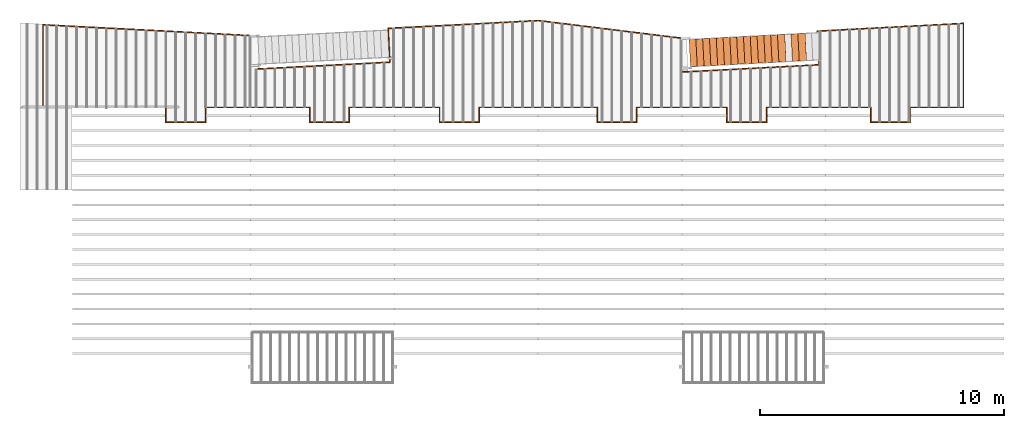
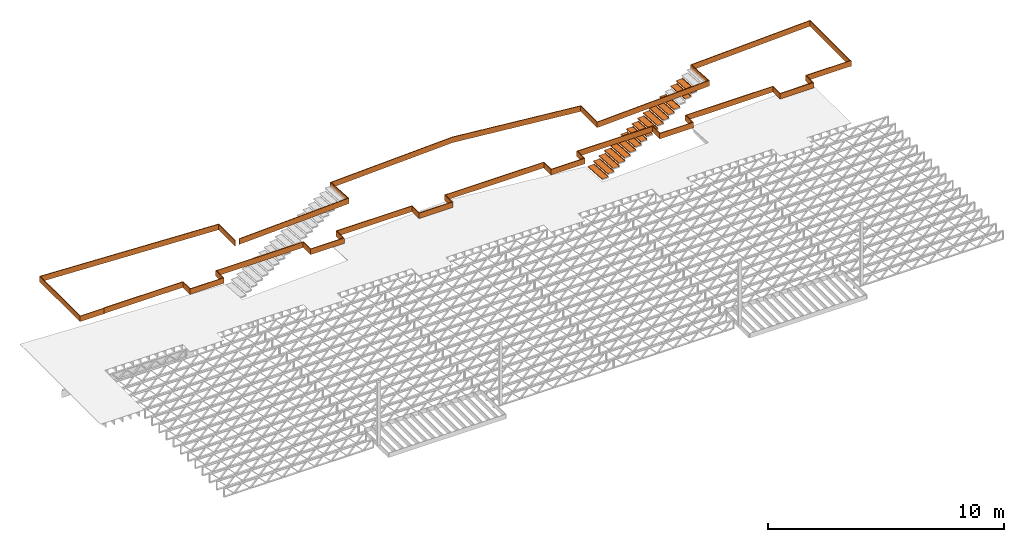
# One storey, part 15 of 23: 18 proxies.
"""IFC4 building model written with IfcOpenShell, lengths in feet."""

from ifc_helpers import new_model, entity, si_unit, converted_unit, derived_unit, direction, frame, origin, place, context, subcontext, project, spatial, polyline, outline, extrude, source, transform, mapped, material, type_object, type_shapes, element, save


model = new_model("IFC4")

# Units and contexts
model_context = context("Model", 3, precision=0.0001, world=origin(), true_north=direction((6.12303176911189e-17, 1.0)))
body_context = subcontext(model_context, "Body", "Model", "MODEL_VIEW")
ifc_project = project(units=[converted_unit("LENGTHUNIT", "FOOT", entity("IfcRatioMeasure", 0.3048), si_unit("LENGTHUNIT", "METRE"), dimensions=[1, 0, 0, 0, 0, 0, 0]), converted_unit("AREAUNIT", "SQUARE FOOT", entity("IfcRatioMeasure", 0.09290304), si_unit("AREAUNIT", "SQUARE_METRE"), dimensions=[2, 0, 0, 0, 0, 0, 0]), converted_unit("VOLUMEUNIT", "CUBIC FOOT", entity("IfcRatioMeasure", 0.028316846592), si_unit("VOLUMEUNIT", "CUBIC_METRE"), dimensions=[3, 0, 0, 0, 0, 0, 0]), converted_unit("PLANEANGLEUNIT", "DEGREE", entity("IfcRatioMeasure", 0.0174532925199433), si_unit("PLANEANGLEUNIT", "RADIAN"), dimensions=[0, 0, 0, 0, 0, 0, 0]), si_unit("MASSUNIT", "GRAM", prefix="KILO"), derived_unit("MASSDENSITYUNIT", [(si_unit("MASSUNIT", "GRAM", prefix="KILO"), 1), (si_unit("LENGTHUNIT", "METRE"), -3)]), derived_unit("MOMENTOFINERTIAUNIT", [(si_unit("LENGTHUNIT", "METRE"), 4)]), si_unit("TIMEUNIT", "SECOND"), si_unit("FREQUENCYUNIT", "HERTZ"), si_unit("THERMODYNAMICTEMPERATUREUNIT", "DEGREE_CELSIUS"), derived_unit("THERMALTRANSMITTANCEUNIT", [(si_unit("MASSUNIT", "GRAM", prefix="KILO"), 1), (si_unit("THERMODYNAMICTEMPERATUREUNIT", "KELVIN"), -1), (si_unit("TIMEUNIT", "SECOND"), -3)]), derived_unit("VOLUMETRICFLOWRATEUNIT", [(si_unit("LENGTHUNIT", "METRE"), 3), (si_unit("TIMEUNIT", "SECOND"), -1)]), si_unit("ELECTRICCURRENTUNIT", "AMPERE"), si_unit("ELECTRICVOLTAGEUNIT", "VOLT"), si_unit("POWERUNIT", "WATT"), si_unit("FORCEUNIT", "NEWTON"), si_unit("ILLUMINANCEUNIT", "LUX"), si_unit("LUMINOUSFLUXUNIT", "LUMEN"), si_unit("LUMINOUSINTENSITYUNIT", "CANDELA"), derived_unit("USERDEFINED", [(si_unit("MASSUNIT", "GRAM", prefix="KILO"), -1), (si_unit("LENGTHUNIT", "METRE"), -2), (si_unit("TIMEUNIT", "SECOND"), 3), (si_unit("LUMINOUSFLUXUNIT", "LUMEN"), 1)]), derived_unit("LINEARVELOCITYUNIT", [(si_unit("LENGTHUNIT", "METRE"), 1), (si_unit("TIMEUNIT", "SECOND"), -1)]), si_unit("PRESSUREUNIT", "PASCAL"), derived_unit("USERDEFINED", [(si_unit("LENGTHUNIT", "METRE"), -2), (si_unit("MASSUNIT", "GRAM", prefix="KILO"), 1), (si_unit("TIMEUNIT", "SECOND"), -2)]), derived_unit("LINEARFORCEUNIT", [(si_unit("MASSUNIT", "GRAM", prefix="KILO"), 1), (si_unit("LENGTHUNIT", "METRE"), 1), (si_unit("TIMEUNIT", "SECOND"), -2), (si_unit("LENGTHUNIT", "METRE"), -1)]), derived_unit("PLANARFORCEUNIT", [(si_unit("MASSUNIT", "GRAM", prefix="KILO"), 1), (si_unit("LENGTHUNIT", "METRE"), 1), (si_unit("TIMEUNIT", "SECOND"), -2), (si_unit("LENGTHUNIT", "METRE"), -2)])], contexts=[model_context])

# Site, building, storey
site_placement = place(None, origin())
site = spatial("IfcSite", under=ifc_project, at=site_placement, CompositionType="ELEMENT")
building_placement = place(site_placement, origin())
building = spatial("IfcBuilding", under=site, at=building_placement, CompositionType="ELEMENT")
storey_placement = place(building_placement, frame((0.0, 0.0, 10.8020833333333)))
storey = spatial("IfcBuildingStorey", under=building, at=storey_placement, Name="2ND FLOOR", CompositionType="ELEMENT", Elevation=10.8020833333333)

# Proxies
ifc_material_1 = material(Name="BRAKE METAL FLASHING AT PERIMETER 2X LEDGER", Category="Materials")
building_element_proxy_type_1 = type_object("IfcBuildingElementProxyType", Name="Structural Framing 10:Structural Framing 10", PredefinedType="NOTDEFINED", material=ifc_material_1)
shared_shape_1 = source(origin(), body_context, "Body", "SweptSolid", [
    extrude(outline(polyline([(-7.56753895396921, -42.2774157655166), (3.87966828565245, -42.2774157655166), (2.84075976230344, -22.4538602254437), (-1.69469338261541, -22.6913475810637), (-2.65710623777287, -4.32741634172971), (1.89079299111185, -4.32741634172969), (4.2646279059843, 15.0059175678136), (3.20329361123053, 35.2573823173956), (-1.33214906717884, 35.0196898385549), (-2.2789485125582, 53.085699471748), (-2.4037772044025, 53.0791574772176), (-1.45043576449265, 34.8883191521804), (3.08500691391683, 35.1260116310211), (4.13922686378191, 15.0102966687023), (1.78020233304241, -4.20241634172977), (-2.7888287534328, -4.20241634172985), (-1.81298037577432, -22.8227126223806), (2.72247276914442, -22.5852252667607), (3.74794576999241, -42.1524157655166), (-7.56753895396921, -42.1524157655166), (-7.56753895396921, -42.2774157655166)])), frame((81.6716675678157, 7.56754075120455, 0.0), z_axis=(0.0, 0.0, 1.0), x_axis=(0.0, 1.0, 0.0)), (0.0, 0.0, 1.0), 0.9375),
    extrude(outline(polyline([(8.04599253803074, -5.11661078283554), (8.04599253803075, -5.24161078283554), (11.9880614770721, -5.24161078283542), (11.9880614770717, 6.03149352153641), (-16.0110697093404, 4.56412123420146), (-16.0110218563282, -0.108947414546855), (-15.8860697093402, -0.115495879087139), (-15.8860697093407, 4.44550066336238), (11.8630614770719, 5.89977100587647), (11.8630614770721, -5.11661078283554), (8.04599253803074, -5.11661078283554)])), frame((11.9880614770724, 5.24161078283623, 0.0), z_axis=(0.0, 0.0, -1.0), x_axis=(-1.0, 0.0, 0.0)), (0.0, 0.0, -1.0), 0.9375),
])
type_shapes(building_element_proxy_type_1, [shared_shape_1])
proxy_1_placement = place(storey_placement, frame((-269.737243818863, 958.903601069585, 9.4687500000001)))
element("IfcBuildingElementProxy", 1, at=proxy_1_placement, inside=storey, type_object=building_element_proxy_type_1, material=ifc_material_1, Name="Structural Framing 10:Structural Framing 10", ObjectType="Structural Framing 10:Structural Framing 10", PredefinedType="NOTDEFINED", context=body_context, shape_type="MappedRepresentation", body=[
    mapped(shared_shape_1, transform((0.0, 0.0, 0.0), scale=1.0)),
])
ifc_material_2 = material(Name="TREATED 2X LEDGER - EXT. STAIN", Category="Materials")
building_element_proxy_type_2 = type_object("IfcBuildingElementProxyType", Name="Structural Framing 30:Structural Framing 10", PredefinedType="NOTDEFINED", material=ifc_material_2)
shared_shape_2 = source(origin(), body_context, "Body", "SweptSolid", [
    extrude(outline(polyline([(-62.5882752409424, -0.860575797798219), (-62.5882752409424, -0.985575797798219), (-49.7925957869951, -0.985575797798219), (-49.7925952844915, 1.01442372247004), (-44.5790513990362, 1.01442372246993), (-44.5790508965316, -0.985580263202678), (-30.4592588644664, -0.985576715578077), (-30.4592593669705, 1.01442372247004), (-25.245716639162, 1.01442372247004), (-25.2457166391621, -0.985579727022696), (-12.9957192201912, -0.98557673237417), (-12.9957197091137, 1.01442372246993), (-7.78738545573532, 1.01442372246981), (-7.78738595421945, -0.985575581580974), (8.21261399126007, -0.985579569456718), (8.21261399126004, 1.01442372247004), (13.4209478126482, 1.01442372247004), (13.4209478126482, -0.985579727024628), (25.6709474765803, -0.985576732373261), (25.6709469876575, 1.01442372246993), (30.8844877145134, 1.01442372247004), (30.884487212011, -0.985575550993076), (45.0042807971791, -0.985579098609605), (45.0042807971789, 1.01442372247027), (50.2126139732988, 1.01442372247038), (50.2126144758024, -0.985575765082217), (57.4959474606437, -0.985577595032396), (57.4959474920499, -0.860577595032169), (50.3376144443961, -0.860575796488433), (50.3376139418926, 1.13942372247061), (44.8792807971786, 1.13942372247061), (44.8792807971788, -0.860579067202821), (31.0094872434177, -0.860575582399179), (31.0094877459201, 1.13942372247027), (25.5459469570995, 1.13942372247027), (25.5459474460225, -0.860576762930805), (13.5459478126485, -0.860579696466743), (13.5459478126485, 1.13942372247038), (8.08761399125981, 1.13942372247027), (8.08761399125981, -0.860579538301181), (-7.66238592306419, -0.860575612736284), (-7.66238542457992, 1.13942372246993), (-13.1207197396713, 1.13942372246981), (-13.1207192507489, -0.860576762931714), (-25.1207166391621, -0.860579696465038), (-25.1207166391621, 1.13942372246993), (-30.584259398377, 1.13942372247004), (-30.584258895873, -0.860576746984407), (-44.4540509279381, -0.860580231796234), (-44.4540514304427, 1.13942372246993), (-49.9175952530849, 1.13942372246993), (-49.9175957555886, -0.860575797798219), (-62.5882752409424, -0.860575797798219)])), frame((62.5882752409424, 1.13942372247061, 0.0), z_axis=(0.0, 0.0, -1.0), x_axis=(1.0, 0.0, 0.0)), (0.0, 0.0, -1.0), 0.9375),
])
type_shapes(building_element_proxy_type_2, [shared_shape_2])
proxy_2_placement = place(storey_placement, frame((-265.872383218523, 956.903601549317, 9.52083333333334)))
element("IfcBuildingElementProxy", 2, at=proxy_2_placement, inside=storey, type_object=building_element_proxy_type_2, material=ifc_material_2, Name="Structural Framing 30:Structural Framing 10", ObjectType="Structural Framing 30:Structural Framing 10", PredefinedType="NOTDEFINED", context=body_context, shape_type="MappedRepresentation", body=[
    mapped(shared_shape_2, transform((0.0, 0.0, 0.0), scale=1.0)),
])
ifc_material_3 = material(Name="GALV. STEEL TREAD", Category="Materials")
building_element_proxy_type_3 = type_object("IfcBuildingElementProxyType", Name="Generic Models 802:Generic Models 629", PredefinedType="NOTDEFINED", material=ifc_material_3)
shared_shape_3 = source(origin(), body_context, "Body", "SweptSolid", [
    extrude(outline(polyline([(-0.597916666666581, 0.02708333333333), (-0.597916666666569, -0.118750000000006), (-0.587499999999929, -0.118750000000006), (-0.587499999999947, 0.0166666666666657), (0.391666666666667, 0.0166666666666657), (0.391666666666679, -0.118750000000006), (0.402083333333376, -0.118750000000006), (0.402083333333369, 0.193750000000001), (0.391666666666649, 0.193750000000001), (0.391666666666667, 0.02708333333333), (-0.597916666666581, 0.02708333333333)])), frame((0.791176413725168, 0.0312925405037277, 0.118750000000009), z_axis=(0.0523359562429694, -0.998629534754573, 0.0), x_axis=(0.998629534754573, 0.0523359562429694, 0.0)), (0.0, 0.0, -1.0), 3.70833333337879),
])
type_shapes(building_element_proxy_type_3, [shared_shape_3])
proxy_3_placement = place(storey_placement, frame((-171.796644235969, 965.013307028824, 6.41392543859246)))
element("IfcBuildingElementProxy", 3, at=proxy_3_placement, inside=storey, type_object=building_element_proxy_type_3, material=ifc_material_3, Name="Generic Models 802:Generic Models 629", ObjectType="Generic Models 802:Generic Models 629", PredefinedType="NOTDEFINED", context=body_context, shape_type="MappedRepresentation", body=[
    mapped(shared_shape_3, transform((0.0, 0.0, 0.0), scale=1.0)),
])
building_element_proxy_type_4 = type_object("IfcBuildingElementProxyType", Name="Generic Models 808:Generic Models 629", PredefinedType="NOTDEFINED", material=ifc_material_3)
shared_shape_4 = source(origin(), body_context, "Body", "SweptSolid", [
    extrude(outline(polyline([(-0.597916666666581, 0.02708333333333), (-0.597916666666569, -0.118750000000006), (-0.587499999999929, -0.118750000000006), (-0.587499999999947, 0.0166666666666657), (0.391666666666667, 0.0166666666666657), (0.391666666666679, -0.118750000000006), (0.402083333333376, -0.118750000000006), (0.402083333333369, 0.193750000000001), (0.391666666666649, 0.193750000000001), (0.391666666666667, 0.02708333333333), (-0.597916666666581, 0.02708333333333)])), frame((0.791176413725168, 0.031292540503614, 0.118750000000006), z_axis=(0.0523359562429694, -0.998629534754573, 0.0), x_axis=(0.998629534754573, 0.0523359562429694, 0.0)), (0.0, 0.0, -1.0), 3.70833333337879),
])
type_shapes(building_element_proxy_type_4, [shared_shape_4])
proxy_4_placement = place(storey_placement, frame((-168.137157266468, 965.205092614211, 8.6595394736803)))
element("IfcBuildingElementProxy", 4, at=proxy_4_placement, inside=storey, type_object=building_element_proxy_type_4, material=ifc_material_3, Name="Generic Models 808:Generic Models 629", ObjectType="Generic Models 808:Generic Models 629", PredefinedType="NOTDEFINED", context=body_context, shape_type="MappedRepresentation", body=[
    mapped(shared_shape_4, transform((0.0, 0.0, 0.0), scale=1.0)),
])
building_element_proxy_type_5 = type_object("IfcBuildingElementProxyType", Name="Generic Models 810:Generic Models 629", PredefinedType="NOTDEFINED", material=ifc_material_3)
shared_shape_5 = source(origin(), body_context, "Body", "SweptSolid", [
    extrude(outline(polyline([(-0.597916666666581, 0.0270833333333336), (-0.597916666666569, -0.118750000000002), (-0.587499999999929, -0.118750000000002), (-0.587499999999947, 0.0166666666666693), (0.391666666666667, 0.0166666666666693), (0.391666666666679, -0.118750000000002), (0.402083333333376, -0.118750000000002), (0.402083333333369, 0.193750000000005), (0.391666666666649, 0.193750000000005), (0.391666666666667, 0.0270833333333336), (-0.597916666666581, 0.0270833333333336)])), frame((0.791176413725168, 0.0312925405038413, 0.118750000000002), z_axis=(0.0523359562429694, -0.998629534754573, 0.0), x_axis=(0.998629534754573, 0.0523359562429694, 0.0)), (0.0, 0.0, -1.0), 3.70833333337879),
])
type_shapes(building_element_proxy_type_5, [shared_shape_5])
proxy_5_placement = place(storey_placement, frame((-169.052029008843, 965.157146217864, 8.09813596490834)))
element("IfcBuildingElementProxy", 5, at=proxy_5_placement, inside=storey, type_object=building_element_proxy_type_5, material=ifc_material_3, Name="Generic Models 810:Generic Models 629", ObjectType="Generic Models 810:Generic Models 629", PredefinedType="NOTDEFINED", context=body_context, shape_type="MappedRepresentation", body=[
    mapped(shared_shape_5, transform((0.0, 0.0, 0.0), scale=1.0)),
])
building_element_proxy_type_6 = type_object("IfcBuildingElementProxyType", Name="Generic Models 814:Generic Models 629", PredefinedType="NOTDEFINED", material=ifc_material_3)
shared_shape_6 = source(origin(), body_context, "Body", "SweptSolid", [
    extrude(outline(polyline([(-0.597916666666581, 0.0270833333333336), (-0.597916666666569, -0.118750000000002), (-0.587499999999929, -0.118750000000002), (-0.587499999999947, 0.0166666666666693), (0.391666666666667, 0.0166666666666693), (0.391666666666679, -0.118750000000002), (0.402083333333376, -0.118750000000002), (0.402083333333369, 0.193750000000005), (0.391666666666649, 0.193750000000005), (0.391666666666667, 0.0270833333333336), (-0.597916666666581, 0.0270833333333336)])), frame((0.791176413725168, 0.0312925405037277, 0.118750000000002), z_axis=(0.0523359562429694, -0.998629534754573, 0.0), x_axis=(0.998629534754573, 0.0523359562429694, 0.0)), (0.0, 0.0, -1.0), 3.70833333337879),
])
type_shapes(building_element_proxy_type_6, [shared_shape_6])
proxy_6_placement = place(storey_placement, frame((-170.881772493594, 965.06125342517, 6.97532894736442)))
element("IfcBuildingElementProxy", 6, at=proxy_6_placement, inside=storey, type_object=building_element_proxy_type_6, material=ifc_material_3, Name="Generic Models 814:Generic Models 629", ObjectType="Generic Models 814:Generic Models 629", PredefinedType="NOTDEFINED", context=body_context, shape_type="MappedRepresentation", body=[
    mapped(shared_shape_6, transform((0.0, 0.0, 0.0), scale=1.0)),
])
building_element_proxy_type_7 = type_object("IfcBuildingElementProxyType", Name="Generic Models 816:Generic Models 629", PredefinedType="NOTDEFINED", material=ifc_material_3)
shared_shape_7 = source(origin(), body_context, "Body", "SweptSolid", [
    extrude(outline(polyline([(-0.597916666666609, 0.0270833333333336), (-0.597916666666598, -0.118750000000002), (-0.587499999999957, -0.118750000000002), (-0.587499999999975, 0.0166666666666693), (0.391666666666639, 0.0166666666666693), (0.39166666666665, -0.118750000000002), (0.402083333333348, -0.118750000000002), (0.40208333333334, 0.193750000000005), (0.391666666666621, 0.193750000000005), (0.391666666666639, 0.0270833333333336), (-0.597916666666609, 0.0270833333333336)])), frame((0.791176413725196, 0.0312925405037277, 0.118750000000002), z_axis=(0.0523359562429694, -0.998629534754573, 0.0), x_axis=(0.998629534754573, 0.0523359562429694, 0.0)), (0.0, 0.0, -1.0), 3.70833333337879),
])
type_shapes(building_element_proxy_type_7, [shared_shape_7])
proxy_7_placement = place(storey_placement, frame((-172.711515978344, 964.965360632477, 5.85252192982051)))
element("IfcBuildingElementProxy", 7, at=proxy_7_placement, inside=storey, type_object=building_element_proxy_type_7, material=ifc_material_3, Name="Generic Models 816:Generic Models 629", ObjectType="Generic Models 816:Generic Models 629", PredefinedType="NOTDEFINED", context=body_context, shape_type="MappedRepresentation", body=[
    mapped(shared_shape_7, transform((0.0, 0.0, 0.0), scale=1.0)),
])
building_element_proxy_type_8 = type_object("IfcBuildingElementProxyType", Name="Generic Models 818:Generic Models 629", PredefinedType="NOTDEFINED", material=ifc_material_3)
shared_shape_8 = source(origin(), body_context, "Body", "SweptSolid", [
    extrude(outline(polyline([(-0.597916666666581, 0.0270833333333336), (-0.597916666666569, -0.118750000000002), (-0.587499999999929, -0.118750000000002), (-0.587499999999947, 0.0166666666666693), (0.391666666666667, 0.0166666666666693), (0.391666666666679, -0.118750000000002), (0.402083333333376, -0.118750000000002), (0.402083333333369, 0.193750000000005), (0.391666666666649, 0.193750000000005), (0.391666666666667, 0.0270833333333336), (-0.597916666666581, 0.0270833333333336)])), frame((0.791176413725168, 0.0312925405037277, 0.118750000000006), z_axis=(0.0523359562429694, -0.998629534754573, 0.0), x_axis=(0.998629534754573, 0.0523359562429694, 0.0)), (0.0, 0.0, -1.0), 3.70833333337879),
])
type_shapes(building_element_proxy_type_8, [shared_shape_8])
proxy_8_placement = place(storey_placement, frame((-173.626387720719, 964.917414236131, 5.29111842104855)))
element("IfcBuildingElementProxy", 8, at=proxy_8_placement, inside=storey, type_object=building_element_proxy_type_8, material=ifc_material_3, Name="Generic Models 818:Generic Models 629", ObjectType="Generic Models 818:Generic Models 629", PredefinedType="NOTDEFINED", context=body_context, shape_type="MappedRepresentation", body=[
    mapped(shared_shape_8, transform((0.0, 0.0, 0.0), scale=1.0)),
])
building_element_proxy_type_9 = type_object("IfcBuildingElementProxyType", Name="Generic Models 820:Generic Models 629", PredefinedType="NOTDEFINED", material=ifc_material_3)
shared_shape_9 = source(origin(), body_context, "Body", "SweptSolid", [
    extrude(outline(polyline([(-0.597916666666609, 0.02708333333333), (-0.597916666666598, -0.118750000000006), (-0.587499999999985, -0.118750000000006), (-0.587499999999975, 0.0166666666666657), (0.391666666666639, 0.0166666666666657), (0.39166666666665, -0.118750000000006), (0.402083333333319, -0.118750000000006), (0.40208333333334, 0.193750000000001), (0.391666666666621, 0.193750000000001), (0.391666666666639, 0.02708333333333), (-0.597916666666609, 0.02708333333333)])), frame((0.791176413725196, 0.031292540503955, 0.118750000000004), z_axis=(0.0523359562429694, -0.998629534754573, 0.0), x_axis=(0.998629534754573, 0.0523359562429694, 0.0)), (0.0, 0.0, -1.0), 3.70833333337879),
])
type_shapes(building_element_proxy_type_9, [shared_shape_9])
proxy_9_placement = place(storey_placement, frame((-174.541259463095, 964.869467839784, 4.7297149122766)))
element("IfcBuildingElementProxy", 9, at=proxy_9_placement, inside=storey, type_object=building_element_proxy_type_9, material=ifc_material_3, Name="Generic Models 820:Generic Models 629", ObjectType="Generic Models 820:Generic Models 629", PredefinedType="NOTDEFINED", context=body_context, shape_type="MappedRepresentation", body=[
    mapped(shared_shape_9, transform((0.0, 0.0, 0.0), scale=1.0)),
])
building_element_proxy_type_10 = type_object("IfcBuildingElementProxyType", Name="Generic Models 822:Generic Models 629", PredefinedType="NOTDEFINED", material=ifc_material_3)
shared_shape_10 = source(origin(), body_context, "Body", "SweptSolid", [
    extrude(outline(polyline([(-0.597916666666581, 0.0270833333333336), (-0.597916666666569, -0.118750000000002), (-0.587499999999929, -0.118750000000002), (-0.587499999999947, 0.0166666666666693), (0.391666666666667, 0.0166666666666693), (0.391666666666679, -0.118750000000002), (0.402083333333376, -0.118750000000002), (0.402083333333369, 0.193750000000005), (0.391666666666649, 0.193750000000005), (0.391666666666667, 0.0270833333333336), (-0.597916666666581, 0.0270833333333336)])), frame((0.791176413725168, 0.031292540503614, 0.11875), z_axis=(0.0523359562429694, -0.998629534754573, 0.0), x_axis=(0.998629534754573, 0.0523359562429694, 0.0)), (0.0, 0.0, -1.0), 3.70833333337879),
])
type_shapes(building_element_proxy_type_10, [shared_shape_10])
proxy_10_placement = place(storey_placement, frame((-175.45613120547, 964.821521443437, 4.16831140350465)))
element("IfcBuildingElementProxy", 10, at=proxy_10_placement, inside=storey, type_object=building_element_proxy_type_10, material=ifc_material_3, Name="Generic Models 822:Generic Models 629", ObjectType="Generic Models 822:Generic Models 629", PredefinedType="NOTDEFINED", context=body_context, shape_type="MappedRepresentation", body=[
    mapped(shared_shape_10, transform((0.0, 0.0, 0.0), scale=1.0)),
])
building_element_proxy_type_11 = type_object("IfcBuildingElementProxyType", Name="Generic Models 824:Generic Models 629", PredefinedType="NOTDEFINED", material=ifc_material_3)
shared_shape_11 = source(origin(), body_context, "Body", "SweptSolid", [
    extrude(outline(polyline([(-0.597916666666609, 0.0270833333333318), (-0.597916666666598, -0.118750000000004), (-0.587499999999957, -0.118750000000004), (-0.587499999999975, 0.0166666666666675), (0.391666666666639, 0.0166666666666675), (0.39166666666665, -0.118750000000004), (0.402083333333348, -0.118750000000004), (0.40208333333334, 0.193750000000003), (0.391666666666621, 0.193750000000003), (0.391666666666639, 0.0270833333333318), (-0.597916666666609, 0.0270833333333318)])), frame((0.791176413725196, 0.0312925405038413, 0.118750000000002), z_axis=(0.0523359562429694, -0.998629534754573, 0.0), x_axis=(0.998629534754573, 0.0523359562429694, 0.0)), (0.0, 0.0, -1.0), 3.70833333337879),
])
type_shapes(building_element_proxy_type_11, [shared_shape_11])
proxy_11_placement = place(storey_placement, frame((-176.371002947845, 964.77357504709, 3.60690789473269)))
element("IfcBuildingElementProxy", 11, at=proxy_11_placement, inside=storey, type_object=building_element_proxy_type_11, material=ifc_material_3, Name="Generic Models 824:Generic Models 629", ObjectType="Generic Models 824:Generic Models 629", PredefinedType="NOTDEFINED", context=body_context, shape_type="MappedRepresentation", body=[
    mapped(shared_shape_11, transform((0.0, 0.0, 0.0), scale=1.0)),
])
building_element_proxy_type_12 = type_object("IfcBuildingElementProxyType", Name="Generic Models 826:Generic Models 629", PredefinedType="NOTDEFINED", material=ifc_material_3)
shared_shape_12 = source(origin(), body_context, "Body", "SweptSolid", [
    extrude(outline(polyline([(-0.597916666666581, 0.0270833333333353), (-0.597916666666569, -0.11875), (-0.587499999999929, -0.11875), (-0.587499999999947, 0.016666666666671), (0.391666666666667, 0.016666666666671), (0.391666666666679, -0.11875), (0.402083333333376, -0.11875), (0.402083333333369, 0.193750000000007), (0.391666666666649, 0.193750000000007), (0.391666666666667, 0.0270833333333353), (-0.597916666666581, 0.0270833333333353)])), frame((0.791176413725168, 0.031292540503614, 0.118749999999999), z_axis=(0.0523359562429694, -0.998629534754573, 0.0), x_axis=(0.998629534754573, 0.0523359562429694, 0.0)), (0.0, 0.0, -1.0), 3.70833333337879),
])
type_shapes(building_element_proxy_type_12, [shared_shape_12])
proxy_12_placement = place(storey_placement, frame((-177.28587469022, 964.725628650744, 3.04550438596073)))
element("IfcBuildingElementProxy", 12, at=proxy_12_placement, inside=storey, type_object=building_element_proxy_type_12, material=ifc_material_3, Name="Generic Models 826:Generic Models 629", ObjectType="Generic Models 826:Generic Models 629", PredefinedType="NOTDEFINED", context=body_context, shape_type="MappedRepresentation", body=[
    mapped(shared_shape_12, transform((0.0, 0.0, 0.0), scale=1.0)),
])
building_element_proxy_type_13 = type_object("IfcBuildingElementProxyType", Name="Generic Models 828:Generic Models 629", PredefinedType="NOTDEFINED", material=ifc_material_3)
shared_shape_13 = source(origin(), body_context, "Body", "SweptSolid", [
    extrude(outline(polyline([(-0.597916666666609, 0.02708333333333), (-0.597916666666598, -0.118750000000006), (-0.587499999999957, -0.118750000000006), (-0.587499999999975, 0.0166666666666657), (0.391666666666639, 0.0166666666666657), (0.39166666666665, -0.118750000000006), (0.402083333333348, -0.118750000000006), (0.40208333333334, 0.193750000000001), (0.391666666666621, 0.193750000000001), (0.391666666666639, 0.02708333333333), (-0.597916666666609, 0.02708333333333)])), frame((0.791176413725196, 0.0312925405038413, 0.118750000000004), z_axis=(0.0523359562429694, -0.998629534754573, 0.0), x_axis=(0.998629534754573, 0.0523359562429694, 0.0)), (0.0, 0.0, -1.0), 3.70833333337879),
])
type_shapes(building_element_proxy_type_13, [shared_shape_13])
proxy_13_placement = place(storey_placement, frame((-178.200746432596, 964.677682254397, 2.48410087718878)))
element("IfcBuildingElementProxy", 13, at=proxy_13_placement, inside=storey, type_object=building_element_proxy_type_13, material=ifc_material_3, Name="Generic Models 828:Generic Models 629", ObjectType="Generic Models 828:Generic Models 629", PredefinedType="NOTDEFINED", context=body_context, shape_type="MappedRepresentation", body=[
    mapped(shared_shape_13, transform((0.0, 0.0, 0.0), scale=1.0)),
])
building_element_proxy_type_14 = type_object("IfcBuildingElementProxyType", Name="Generic Models 830:Generic Models 629", PredefinedType="NOTDEFINED", material=ifc_material_3)
shared_shape_14 = source(origin(), body_context, "Body", "SweptSolid", [
    extrude(outline(polyline([(-0.597916666666581, 0.0270833333333336), (-0.597916666666569, -0.118750000000002), (-0.587499999999929, -0.118750000000002), (-0.587499999999947, 0.0166666666666693), (0.391666666666667, 0.0166666666666693), (0.391666666666679, -0.118750000000002), (0.402083333333376, -0.118750000000002), (0.402083333333369, 0.193750000000005), (0.391666666666649, 0.193750000000005), (0.391666666666667, 0.0270833333333336), (-0.597916666666581, 0.0270833333333336)])), frame((0.791176413725168, 0.0312925405037277, 0.11875), z_axis=(0.0523359562429694, -0.998629534754573, 0.0), x_axis=(0.998629534754573, 0.0523359562429694, 0.0)), (0.0, 0.0, -1.0), 3.70833333337879),
])
type_shapes(building_element_proxy_type_14, [shared_shape_14])
proxy_14_placement = place(storey_placement, frame((-179.115618174971, 964.62973585805, 1.92269736841682)))
element("IfcBuildingElementProxy", 14, at=proxy_14_placement, inside=storey, type_object=building_element_proxy_type_14, material=ifc_material_3, Name="Generic Models 830:Generic Models 629", ObjectType="Generic Models 830:Generic Models 629", PredefinedType="NOTDEFINED", context=body_context, shape_type="MappedRepresentation", body=[
    mapped(shared_shape_14, transform((0.0, 0.0, 0.0), scale=1.0)),
])
building_element_proxy_type_15 = type_object("IfcBuildingElementProxyType", Name="Generic Models 832:Generic Models 629", PredefinedType="NOTDEFINED", material=ifc_material_3)
shared_shape_15 = source(origin(), body_context, "Body", "SweptSolid", [
    extrude(outline(polyline([(-0.597916666666609, 0.0270833333333318), (-0.597916666666598, -0.118750000000004), (-0.587499999999985, -0.118750000000004), (-0.587499999999975, 0.0166666666666675), (0.391666666666639, 0.0166666666666675), (0.39166666666665, -0.118750000000004), (0.402083333333319, -0.118750000000004), (0.40208333333334, 0.193750000000003), (0.391666666666621, 0.193750000000003), (0.391666666666639, 0.0270833333333318), (-0.597916666666609, 0.0270833333333318)])), frame((0.791176413725196, 0.031292540503955, 0.118750000000002), z_axis=(0.0523359562429694, -0.998629534754573, 0.0), x_axis=(0.998629534754573, 0.0523359562429694, 0.0)), (0.0, 0.0, -1.0), 3.70833333337879),
])
type_shapes(building_element_proxy_type_15, [shared_shape_15])
proxy_15_placement = place(storey_placement, frame((-180.030489917346, 964.581789461704, 1.36129385964486)))
element("IfcBuildingElementProxy", 15, at=proxy_15_placement, inside=storey, type_object=building_element_proxy_type_15, material=ifc_material_3, Name="Generic Models 832:Generic Models 629", ObjectType="Generic Models 832:Generic Models 629", PredefinedType="NOTDEFINED", context=body_context, shape_type="MappedRepresentation", body=[
    mapped(shared_shape_15, transform((0.0, 0.0, 0.0), scale=1.0)),
])
building_element_proxy_type_16 = type_object("IfcBuildingElementProxyType", Name="Generic Models 834:Generic Models 629", PredefinedType="NOTDEFINED", material=ifc_material_3)
shared_shape_16 = source(origin(), body_context, "Body", "SweptSolid", [
    extrude(outline(polyline([(-0.597916666666581, 0.0270833333333353), (-0.597916666666569, -0.11875), (-0.587499999999929, -0.11875), (-0.587499999999947, 0.016666666666671), (0.391666666666667, 0.016666666666671), (0.391666666666679, -0.11875), (0.402083333333376, -0.11875), (0.402083333333369, 0.193750000000007), (0.391666666666649, 0.193750000000007), (0.391666666666667, 0.0270833333333353), (-0.597916666666581, 0.0270833333333353)])), frame((0.791176413725168, 0.0312925405037277, 0.118749999999999), z_axis=(0.0523359562429694, -0.998629534754573, 0.0), x_axis=(0.998629534754573, 0.0523359562429694, 0.0)), (0.0, 0.0, -1.0), 3.70833333337879),
])
type_shapes(building_element_proxy_type_16, [shared_shape_16])
proxy_16_placement = place(storey_placement, frame((-180.945361659721, 964.533843065357, 0.799890350872907)))
element("IfcBuildingElementProxy", 16, at=proxy_16_placement, inside=storey, type_object=building_element_proxy_type_16, material=ifc_material_3, Name="Generic Models 834:Generic Models 629", ObjectType="Generic Models 834:Generic Models 629", PredefinedType="NOTDEFINED", context=body_context, shape_type="MappedRepresentation", body=[
    mapped(shared_shape_16, transform((0.0, 0.0, 0.0), scale=1.0)),
])
building_element_proxy_type_17 = type_object("IfcBuildingElementProxyType", Name="Generic Models 836:Generic Models 629", PredefinedType="NOTDEFINED", material=ifc_material_3)
shared_shape_17 = source(origin(), body_context, "Body", "SweptSolid", [
    extrude(outline(polyline([(-0.597916666666609, 0.02708333333333), (-0.597916666666598, -0.118750000000006), (-0.587499999999957, -0.118750000000006), (-0.587499999999975, 0.0166666666666657), (0.391666666666639, 0.0166666666666657), (0.39166666666665, -0.118750000000006), (0.402083333333348, -0.118750000000006), (0.40208333333334, 0.193750000000001), (0.391666666666621, 0.193750000000001), (0.391666666666639, 0.02708333333333), (-0.597916666666609, 0.02708333333333)])), frame((0.791176413725196, 0.0312925405037277, 0.118750000000004), z_axis=(0.0523359562429694, -0.998629534754573, 0.0), x_axis=(0.998629534754573, 0.0523359562429694, 0.0)), (0.0, 0.0, -1.0), 3.70833333337879),
])
type_shapes(building_element_proxy_type_17, [shared_shape_17])
proxy_17_placement = place(storey_placement, frame((-181.860233402096, 964.48589666901, 0.238486842100951)))
element("IfcBuildingElementProxy", 17, at=proxy_17_placement, inside=storey, type_object=building_element_proxy_type_17, material=ifc_material_3, Name="Generic Models 836:Generic Models 629", ObjectType="Generic Models 836:Generic Models 629", PredefinedType="NOTDEFINED", context=body_context, shape_type="MappedRepresentation", body=[
    mapped(shared_shape_17, transform((0.0, 0.0, 0.0), scale=1.0)),
])
building_element_proxy_type_18 = type_object("IfcBuildingElementProxyType", Name="Generic Models 838:Generic Models 629", PredefinedType="NOTDEFINED", material=ifc_material_3)
shared_shape_18 = source(origin(), body_context, "Body", "SweptSolid", [
    extrude(outline(polyline([(-0.597916666666581, 0.0270833333333318), (-0.597916666666569, -0.118750000000004), (-0.587499999999929, -0.118750000000004), (-0.587499999999947, 0.0166666666666675), (0.391666666666667, 0.0166666666666675), (0.391666666666679, -0.118750000000004), (0.402083333333376, -0.118750000000004), (0.402083333333369, 0.193750000000003), (0.391666666666649, 0.193750000000003), (0.391666666666667, 0.0270833333333318), (-0.597916666666581, 0.0270833333333318)])), frame((0.791176413725168, 0.031292540503614, 0.118750000000002), z_axis=(0.0523359562429694, -0.998629534754573, 0.0), x_axis=(0.998629534754573, 0.0523359562429694, 0.0)), (0.0, 0.0, -1.0), 3.70833333337879),
])
type_shapes(building_element_proxy_type_18, [shared_shape_18])
proxy_18_placement = place(storey_placement, frame((-182.775105144472, 964.437950272664, -0.322916666671006)))
element("IfcBuildingElementProxy", 18, at=proxy_18_placement, inside=storey, type_object=building_element_proxy_type_18, material=ifc_material_3, Name="Generic Models 838:Generic Models 629", ObjectType="Generic Models 838:Generic Models 629", PredefinedType="NOTDEFINED", context=body_context, shape_type="MappedRepresentation", body=[
    mapped(shared_shape_18, transform((0.0, 0.0, 0.0), scale=1.0)),
])

save(model, "model.ifc")
